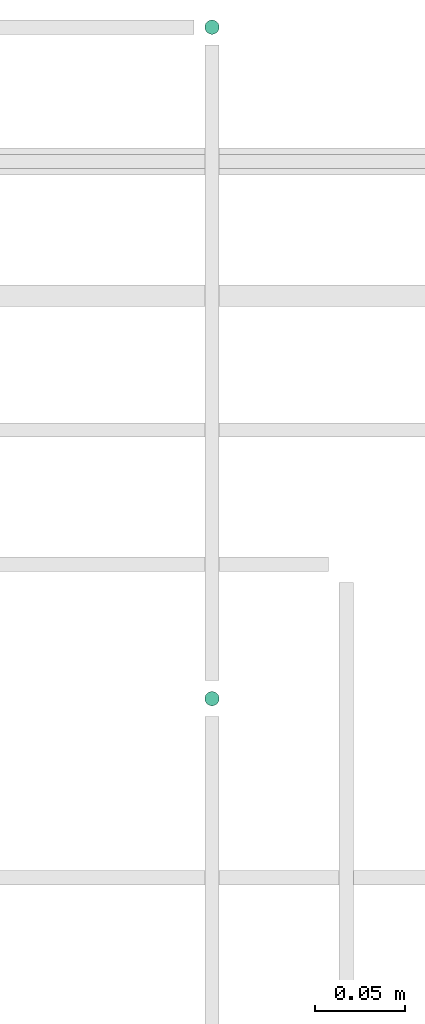
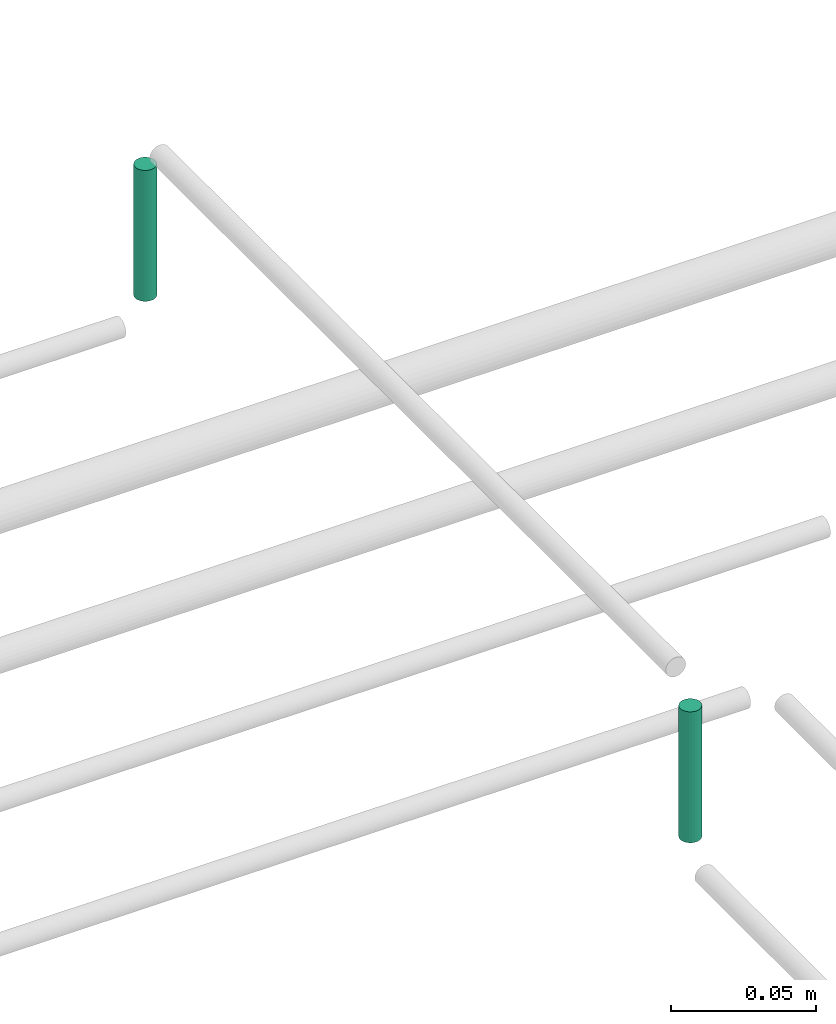
# One storey, part 323 of 331: 2 flow segments.
"""IFC2X3 building model written with IfcOpenShell, lengths in millimetres."""

from ifc_helpers import new_model, entity, si_unit, converted_unit, derived_unit, direction, frame, origin, origin_2d_with_axis, place, context, subcontext, project, spatial, circle, extrude, type_object, element, save


model = new_model("IFC2X3")

# Units and contexts
model_context = context("Model", 3, precision=0.01, world=origin(), true_north=direction((6.12303176911189e-17, 1.0)))
body_context = subcontext(model_context, "Body", "Model", "MODEL_VIEW")
ifc_project = project(units=[si_unit("LENGTHUNIT", "METRE", prefix="MILLI"), si_unit("AREAUNIT", "SQUARE_METRE"), si_unit("VOLUMEUNIT", "CUBIC_METRE"), converted_unit("PLANEANGLEUNIT", "DEGREE", entity("IfcRatioMeasure", 0.0174532925199433), si_unit("PLANEANGLEUNIT", "RADIAN"), dimensions=[0, 0, 0, 0, 0, 0, 0]), si_unit("MASSUNIT", "GRAM", prefix="KILO"), derived_unit("MASSDENSITYUNIT", [(si_unit("MASSUNIT", "GRAM", prefix="KILO"), 1), (si_unit("LENGTHUNIT", "METRE"), -3)]), derived_unit("MOMENTOFINERTIAUNIT", [(si_unit("LENGTHUNIT", "METRE"), 4)]), si_unit("TIMEUNIT", "SECOND"), si_unit("FREQUENCYUNIT", "HERTZ"), si_unit("THERMODYNAMICTEMPERATUREUNIT", "DEGREE_CELSIUS"), derived_unit("THERMALTRANSMITTANCEUNIT", [(si_unit("MASSUNIT", "GRAM", prefix="KILO"), 1), (si_unit("THERMODYNAMICTEMPERATUREUNIT", "KELVIN"), -1), (si_unit("TIMEUNIT", "SECOND"), -3)]), derived_unit("VOLUMETRICFLOWRATEUNIT", [(si_unit("LENGTHUNIT", "METRE"), 3), (si_unit("TIMEUNIT", "SECOND"), -1)]), derived_unit("MASSFLOWRATEUNIT", [(si_unit("MASSUNIT", "GRAM", prefix="KILO"), 1), (si_unit("TIMEUNIT", "SECOND"), -1)]), derived_unit("ROTATIONALFREQUENCYUNIT", [(si_unit("TIMEUNIT", "SECOND"), -1)]), si_unit("ELECTRICCURRENTUNIT", "AMPERE"), si_unit("ELECTRICVOLTAGEUNIT", "VOLT"), si_unit("POWERUNIT", "WATT"), si_unit("FORCEUNIT", "NEWTON", prefix="KILO"), si_unit("ILLUMINANCEUNIT", "LUX"), si_unit("LUMINOUSFLUXUNIT", "LUMEN"), si_unit("LUMINOUSINTENSITYUNIT", "CANDELA"), derived_unit("USERDEFINED", [(si_unit("MASSUNIT", "GRAM", prefix="KILO"), -1), (si_unit("LENGTHUNIT", "METRE"), -2), (si_unit("TIMEUNIT", "SECOND"), 3), (si_unit("LUMINOUSFLUXUNIT", "LUMEN"), 1)]), derived_unit("LINEARVELOCITYUNIT", [(si_unit("LENGTHUNIT", "METRE"), 1), (si_unit("TIMEUNIT", "SECOND"), -1)]), si_unit("PRESSUREUNIT", "PASCAL"), derived_unit("USERDEFINED", [(si_unit("LENGTHUNIT", "METRE"), -2), (si_unit("MASSUNIT", "GRAM", prefix="KILO"), 1), (si_unit("TIMEUNIT", "SECOND"), -2)]), derived_unit("LINEARFORCEUNIT", [(si_unit("MASSUNIT", "GRAM", prefix="KILO"), 1), (si_unit("LENGTHUNIT", "METRE"), 1), (si_unit("TIMEUNIT", "SECOND"), -2), (si_unit("LENGTHUNIT", "METRE"), -1)]), derived_unit("PLANARFORCEUNIT", [(si_unit("MASSUNIT", "GRAM", prefix="KILO"), 1), (si_unit("LENGTHUNIT", "METRE"), 1), (si_unit("TIMEUNIT", "SECOND"), -2), (si_unit("LENGTHUNIT", "METRE"), -2)])], contexts=[model_context])

# Site, building, storey
site_placement = place(None, frame((0.0, -0.00077364408347762, 0.0)))
site = spatial("IfcSite", under=ifc_project, at=site_placement, CompositionType="ELEMENT")
building_placement = place(site_placement, origin())
building = spatial("IfcBuilding", under=site, at=building_placement, CompositionType="ELEMENT")
storey_placement = place(building_placement, origin())
storey = spatial("IfcBuildingStorey", under=building, at=storey_placement, CompositionType="ELEMENT", Elevation=0.0)

# Flow segments
pipe_segment_type = type_object("IfcPipeSegmentType", PredefinedType="NOTDEFINED")
flow_segment_1_placement = place(building_placement, frame((58271.5947663297, 19844.4039541202, 19060.0)))
element("IfcFlowSegment", 1, at=flow_segment_1_placement, inside=storey, type_object=pipe_segment_type, context=body_context, shape_type="SweptSolid", body=[
    extrude(circle(Radius=4.0, at=origin_2d_with_axis()), frame((5.59527223591499, 5.59527223591499, 0.0), z_axis=(0.0, 0.0, 1.0), x_axis=(-1.0, 0.0, 0.0)), (0.0, 0.0, 1.0), 54.9999999999962),
])
flow_segment_2_placement = place(building_placement, frame((58271.5947663297, 20219.4039541202, 19060.0)))
element("IfcFlowSegment", 2, at=flow_segment_2_placement, inside=storey, type_object=pipe_segment_type, context=body_context, shape_type="SweptSolid", body=[
    extrude(circle(Radius=4.0, at=origin_2d_with_axis()), frame((5.59527223591499, 5.59527223591499, 0.0)), (0.0, 0.0, 1.0), 55.0000000000113),
])

save(model, "model.ifc")
